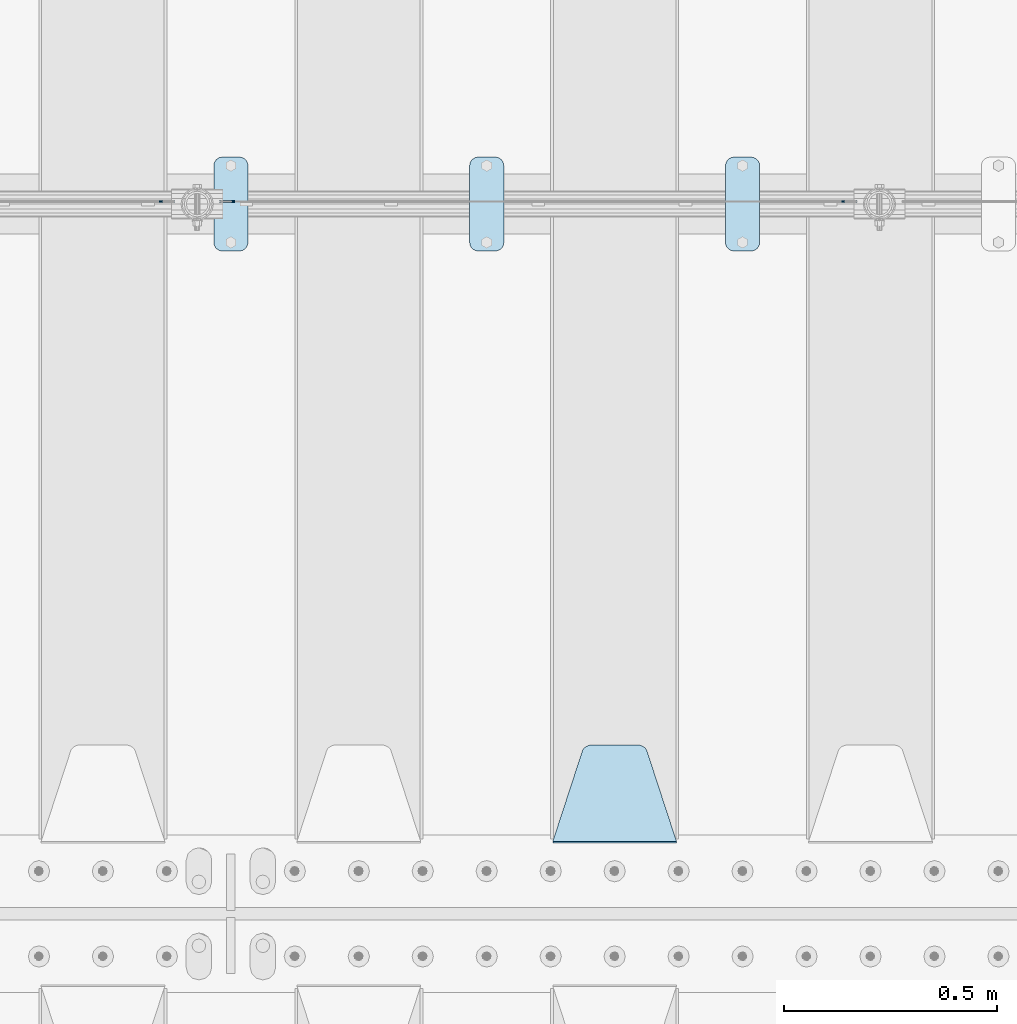
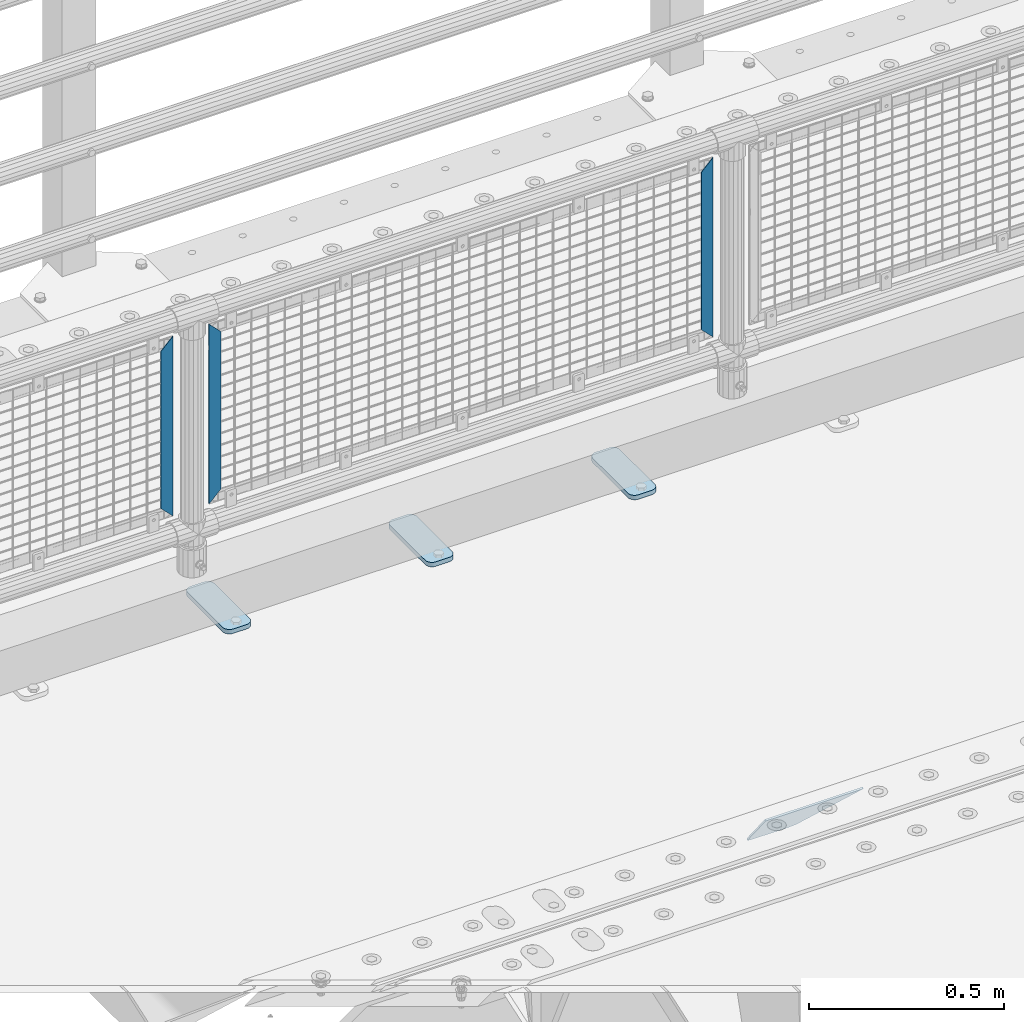
# One storey, part 174 of 208: 7 plates.
"""IFC2X3 building model written with IfcOpenShell, lengths in millimetres."""

from ifc_helpers import new_model, si_unit, frame, origin_with_axes, place, context, subcontext, project, spatial, faceted_brep, material, type_object, element, save


model = new_model("IFC2X3")

# Units and contexts
model_context = context("Model", 3, precision=1e-05, world=origin_with_axes())
body_context = subcontext(model_context, "Body", "Model", "MODEL_VIEW")
ifc_project = project(units=[si_unit("LENGTHUNIT", "METRE", prefix="MILLI"), si_unit("AREAUNIT", "SQUARE_METRE"), si_unit("VOLUMEUNIT", "CUBIC_METRE"), si_unit("MASSUNIT", "GRAM", prefix="KILO"), si_unit("TIMEUNIT", "SECOND"), si_unit("PLANEANGLEUNIT", "RADIAN"), si_unit("SOLIDANGLEUNIT", "STERADIAN"), si_unit("THERMODYNAMICTEMPERATUREUNIT", "DEGREE_CELSIUS"), si_unit("LUMINOUSINTENSITYUNIT", "LUMEN")], contexts=[model_context])

# Site, building, storey
site_placement = place(None, origin_with_axes())
site = spatial("IfcSite", under=ifc_project, at=site_placement, CompositionType="ELEMENT")
building_placement = place(site_placement, origin_with_axes())
building = spatial("IfcBuilding", under=site, at=building_placement, Name="Standard", CompositionType="ELEMENT")
storey_placement = place(building_placement, origin_with_axes())
storey = spatial("IfcBuildingStorey", under=building, at=storey_placement, Name="Undefined", CompositionType="ELEMENT", Elevation=0.0)

# Plates
ifc_material_1 = material(Name="STEEL/S355J2")
plate_type_1 = type_object("IfcPlateType", PredefinedType="NOTDEFINED")
plate_1_placement = place(storey_placement, frame((-35790.0, 4774.5, 21.0199999999977), z_axis=(1.0, 0.0, 0.0), x_axis=(0.0, -1.0, 0.0)))
element("IfcPlate", 1, at=plate_1_placement, inside=storey, type_object=plate_type_1, material=ifc_material_1, context=body_context, shape_type="Brep", body=[
    faceted_brep([(0.0, -7.0, 20.0), (0.0, -7.0, 60.0), (0.0, 7.0, 60.0), (0.0, 7.0, 20.0), (0.384294391935327, -7.0, 63.9018064403208), (0.384294391935327, 7.0, 63.9018064403208), (1.52240934977453, -7.0, 67.6536686473009), (1.52240934977453, 7.0, 67.6536686473009), (3.37060775394912, -7.0, 71.1114046603907), (3.37060775394912, 7.0, 71.1114046603907), (5.85786437626939, -7.0, 74.1421356237297), (5.85786437626939, 7.0, 74.1421356237297), (8.8885953396084, -7.0, 76.62939224605), (8.8885953396084, 7.0, 76.62939224605), (12.3463313526981, -7.0, 78.4775906502255), (12.3463313526981, 7.0, 78.4775906502255), (16.0981935596774, -7.0, 79.6157056080629), (16.0981935596774, 7.0, 79.6157056080629), (20.0, -7.0, 80.0), (20.0, 7.0, 80.0), (200.0, -7.0, 80.0), (200.0, 7.0, 80.0), (203.901806440323, -7.0, 79.6157056080629), (203.901806440323, 7.0, 79.6157056080629), (207.653668647302, -7.0, 78.4775906502255), (207.653668647302, 7.0, 78.4775906502255), (211.111404660393, -7.0, 76.62939224605), (211.111404660393, 7.0, 76.62939224605), (214.142135623731, -7.0, 74.1421356237297), (214.142135623731, 7.0, 74.1421356237297), (216.629392246051, -7.0, 71.1114046603907), (216.629392246051, 7.0, 71.1114046603907), (218.477590650225, -7.0, 67.6536686473009), (218.477590650225, 7.0, 67.6536686473009), (219.615705608065, -7.0, 63.9018064403208), (219.615705608065, 7.0, 63.9018064403208), (220.0, -7.0, 60.0), (220.0, 7.0, 60.0), (220.0, -7.0, 20.0), (220.0, 7.0, 20.0), (219.615705608065, -7.0, 16.0981935596792), (219.615705608065, 7.0, 16.0981935596792), (218.477590650225, -7.0, 12.3463313526991), (218.477590650225, 7.0, 12.3463313526991), (216.629392246051, -7.0, 8.88859533960931), (216.629392246051, 7.0, 8.88859533960931), (214.142135623731, -7.0, 5.8578643762703), (214.142135623731, 7.0, 5.8578643762703), (211.111404660393, -7.0, 3.37060775395003), (211.111404660393, 7.0, 3.37060775395003), (207.653668647302, -7.0, 1.52240934977453), (207.653668647302, 7.0, 1.52240934977453), (203.901806440323, -7.0, 0.384294391937146), (203.901806440323, 7.0, 0.384294391937146), (200.0, -7.0, 0.0), (200.0, 7.0, 0.0), (20.0, -7.0, 0.0), (20.0, 7.0, 0.0), (16.0981935596774, -7.0, 0.384294391937146), (16.0981935596774, 7.0, 0.384294391937146), (12.3463313526981, -7.0, 1.52240934977453), (12.3463313526981, 7.0, 1.52240934977453), (8.8885953396084, -7.0, 3.37060775395003), (8.8885953396084, 7.0, 3.37060775395003), (5.85786437626939, -7.0, 5.8578643762703), (5.85786437626939, 7.0, 5.8578643762703), (3.37060775394912, -7.0, 8.88859533960931), (3.37060775394912, 7.0, 8.88859533960931), (1.52240934977453, -7.0, 12.3463313526991), (1.52240934977453, 7.0, 12.3463313526991), (0.384294391935327, -7.0, 16.0981935596792), (0.384294391935327, 7.0, 16.0981935596792)], [[[0, 1, 2, 3]], [[1, 4, 5, 2]], [[4, 6, 7, 5]], [[6, 8, 9, 7]], [[8, 10, 11, 9]], [[10, 12, 13, 11]], [[12, 14, 15, 13]], [[14, 16, 17, 15]], [[16, 18, 19, 17]], [[18, 20, 21, 19]], [[20, 22, 23, 21]], [[22, 24, 25, 23]], [[24, 26, 27, 25]], [[26, 28, 29, 27]], [[28, 30, 31, 29]], [[30, 32, 33, 31]], [[32, 34, 35, 33]], [[34, 36, 37, 35]], [[36, 38, 39, 37]], [[38, 40, 41, 39]], [[40, 42, 43, 41]], [[42, 44, 45, 43]], [[44, 46, 47, 45]], [[46, 48, 49, 47]], [[48, 50, 51, 49]], [[50, 52, 53, 51]], [[52, 54, 55, 53]], [[54, 56, 57, 55]], [[56, 58, 59, 57]], [[58, 60, 61, 59]], [[60, 62, 63, 61]], [[62, 64, 65, 63]], [[64, 66, 67, 65]], [[66, 68, 69, 67]], [[68, 70, 71, 69]], [[70, 0, 3, 71]], [[5, 7, 9, 11, 13, 15, 17, 19, 21, 23, 25, 27, 29, 31, 33, 35, 37, 39, 41, 43, 45, 47, 49, 51, 53, 55, 57, 59, 61, 63, 65, 67, 69, 71, 3, 2]], [[70, 68, 66, 64, 62, 60, 58, 56, 54, 52, 50, 48, 46, 44, 42, 40, 38, 36, 34, 32, 30, 28, 26, 24, 22, 20, 18, 16, 14, 12, 10, 8, 6, 4, 1, 0]]]),
])
plate_2_placement = place(storey_placement, frame((-36390.0, 4774.5, 21.0199999999977), z_axis=(1.0, 0.0, 0.0), x_axis=(0.0, -1.0, 0.0)))
element("IfcPlate", 2, at=plate_2_placement, inside=storey, type_object=plate_type_1, material=ifc_material_1, context=body_context, shape_type="Brep", body=[
    faceted_brep([(0.0, -7.0, 20.0), (0.0, -7.0, 60.0), (0.0, 7.0, 60.0), (0.0, 7.0, 20.0), (0.384294391935327, -7.0, 63.9018064403208), (0.384294391935327, 7.0, 63.9018064403208), (1.52240934977453, -7.0, 67.6536686473009), (1.52240934977453, 7.0, 67.6536686473009), (3.37060775394912, -7.0, 71.1114046603907), (3.37060775394912, 7.0, 71.1114046603907), (5.85786437626939, -7.0, 74.1421356237297), (5.85786437626939, 7.0, 74.1421356237297), (8.8885953396084, -7.0, 76.62939224605), (8.8885953396084, 7.0, 76.62939224605), (12.3463313526981, -7.0, 78.4775906502255), (12.3463313526981, 7.0, 78.4775906502255), (16.0981935596774, -7.0, 79.6157056080629), (16.0981935596774, 7.0, 79.6157056080629), (20.0, -7.0, 80.0), (20.0, 7.0, 80.0), (200.0, -7.0, 80.0), (200.0, 7.0, 80.0), (203.901806440323, -7.0, 79.6157056080629), (203.901806440323, 7.0, 79.6157056080629), (207.653668647302, -7.0, 78.4775906502255), (207.653668647302, 7.0, 78.4775906502255), (211.111404660393, -7.0, 76.62939224605), (211.111404660393, 7.0, 76.62939224605), (214.142135623731, -7.0, 74.1421356237297), (214.142135623731, 7.0, 74.1421356237297), (216.629392246051, -7.0, 71.1114046603907), (216.629392246051, 7.0, 71.1114046603907), (218.477590650225, -7.0, 67.6536686473009), (218.477590650225, 7.0, 67.6536686473009), (219.615705608065, -7.0, 63.9018064403208), (219.615705608065, 7.0, 63.9018064403208), (220.0, -7.0, 60.0), (220.0, 7.0, 60.0), (220.0, -7.0, 20.0), (220.0, 7.0, 20.0), (219.615705608065, -7.0, 16.0981935596792), (219.615705608065, 7.0, 16.0981935596792), (218.477590650225, -7.0, 12.3463313526991), (218.477590650225, 7.0, 12.3463313526991), (216.629392246051, -7.0, 8.88859533960931), (216.629392246051, 7.0, 8.88859533960931), (214.142135623731, -7.0, 5.8578643762703), (214.142135623731, 7.0, 5.8578643762703), (211.111404660393, -7.0, 3.37060775395003), (211.111404660393, 7.0, 3.37060775395003), (207.653668647302, -7.0, 1.52240934977453), (207.653668647302, 7.0, 1.52240934977453), (203.901806440323, -7.0, 0.384294391937146), (203.901806440323, 7.0, 0.384294391937146), (200.0, -7.0, 0.0), (200.0, 7.0, 0.0), (20.0, -7.0, 0.0), (20.0, 7.0, 0.0), (16.0981935596774, -7.0, 0.384294391937146), (16.0981935596774, 7.0, 0.384294391937146), (12.3463313526981, -7.0, 1.52240934977453), (12.3463313526981, 7.0, 1.52240934977453), (8.8885953396084, -7.0, 3.37060775395003), (8.8885953396084, 7.0, 3.37060775395003), (5.85786437626939, -7.0, 5.8578643762703), (5.85786437626939, 7.0, 5.8578643762703), (3.37060775394912, -7.0, 8.88859533960931), (3.37060775394912, 7.0, 8.88859533960931), (1.52240934977453, -7.0, 12.3463313526991), (1.52240934977453, 7.0, 12.3463313526991), (0.384294391935327, -7.0, 16.0981935596792), (0.384294391935327, 7.0, 16.0981935596792)], [[[0, 1, 2, 3]], [[1, 4, 5, 2]], [[4, 6, 7, 5]], [[6, 8, 9, 7]], [[8, 10, 11, 9]], [[10, 12, 13, 11]], [[12, 14, 15, 13]], [[14, 16, 17, 15]], [[16, 18, 19, 17]], [[18, 20, 21, 19]], [[20, 22, 23, 21]], [[22, 24, 25, 23]], [[24, 26, 27, 25]], [[26, 28, 29, 27]], [[28, 30, 31, 29]], [[30, 32, 33, 31]], [[32, 34, 35, 33]], [[34, 36, 37, 35]], [[36, 38, 39, 37]], [[38, 40, 41, 39]], [[40, 42, 43, 41]], [[42, 44, 45, 43]], [[44, 46, 47, 45]], [[46, 48, 49, 47]], [[48, 50, 51, 49]], [[50, 52, 53, 51]], [[52, 54, 55, 53]], [[54, 56, 57, 55]], [[56, 58, 59, 57]], [[58, 60, 61, 59]], [[60, 62, 63, 61]], [[62, 64, 65, 63]], [[64, 66, 67, 65]], [[66, 68, 69, 67]], [[68, 70, 71, 69]], [[70, 0, 3, 71]], [[5, 7, 9, 11, 13, 15, 17, 19, 21, 23, 25, 27, 29, 31, 33, 35, 37, 39, 41, 43, 45, 47, 49, 51, 53, 55, 57, 59, 61, 63, 65, 67, 69, 71, 3, 2]], [[70, 68, 66, 64, 62, 60, 58, 56, 54, 52, 50, 48, 46, 44, 42, 40, 38, 36, 34, 32, 30, 28, 26, 24, 22, 20, 18, 16, 14, 12, 10, 8, 6, 4, 1, 0]]]),
])
plate_3_placement = place(storey_placement, frame((-36990.0, 4774.5, 21.0199999999977), z_axis=(1.0, 0.0, 0.0), x_axis=(0.0, -1.0, 0.0)))
element("IfcPlate", 3, at=plate_3_placement, inside=storey, type_object=plate_type_1, material=ifc_material_1, context=body_context, shape_type="Brep", body=[
    faceted_brep([(0.0, -7.0, 20.0), (0.0, -7.0, 60.0), (0.0, 7.0, 60.0), (0.0, 7.0, 20.0), (0.384294391935327, -7.0, 63.9018064403208), (0.384294391935327, 7.0, 63.9018064403208), (1.52240934977453, -7.0, 67.6536686473009), (1.52240934977453, 7.0, 67.6536686473009), (3.37060775394912, -7.0, 71.1114046603907), (3.37060775394912, 7.0, 71.1114046603907), (5.85786437626939, -7.0, 74.1421356237297), (5.85786437626939, 7.0, 74.1421356237297), (8.8885953396084, -7.0, 76.62939224605), (8.8885953396084, 7.0, 76.62939224605), (12.3463313526981, -7.0, 78.4775906502255), (12.3463313526981, 7.0, 78.4775906502255), (16.0981935596774, -7.0, 79.6157056080629), (16.0981935596774, 7.0, 79.6157056080629), (20.0, -7.0, 80.0), (20.0, 7.0, 80.0), (200.0, -7.0, 80.0), (200.0, 7.0, 80.0), (203.901806440323, -7.0, 79.6157056080629), (203.901806440323, 7.0, 79.6157056080629), (207.653668647302, -7.0, 78.4775906502255), (207.653668647302, 7.0, 78.4775906502255), (211.111404660393, -7.0, 76.62939224605), (211.111404660393, 7.0, 76.62939224605), (214.142135623731, -7.0, 74.1421356237297), (214.142135623731, 7.0, 74.1421356237297), (216.629392246051, -7.0, 71.1114046603907), (216.629392246051, 7.0, 71.1114046603907), (218.477590650225, -7.0, 67.6536686473009), (218.477590650225, 7.0, 67.6536686473009), (219.615705608065, -7.0, 63.9018064403208), (219.615705608065, 7.0, 63.9018064403208), (220.0, -7.0, 60.0), (220.0, 7.0, 60.0), (220.0, -7.0, 20.0), (220.0, 7.0, 20.0), (219.615705608065, -7.0, 16.0981935596792), (219.615705608065, 7.0, 16.0981935596792), (218.477590650225, -7.0, 12.3463313526991), (218.477590650225, 7.0, 12.3463313526991), (216.629392246051, -7.0, 8.88859533960931), (216.629392246051, 7.0, 8.88859533960931), (214.142135623731, -7.0, 5.8578643762703), (214.142135623731, 7.0, 5.8578643762703), (211.111404660393, -7.0, 3.37060775395003), (211.111404660393, 7.0, 3.37060775395003), (207.653668647302, -7.0, 1.52240934977453), (207.653668647302, 7.0, 1.52240934977453), (203.901806440323, -7.0, 0.384294391937146), (203.901806440323, 7.0, 0.384294391937146), (200.0, -7.0, 0.0), (200.0, 7.0, 0.0), (20.0, -7.0, 0.0), (20.0, 7.0, 0.0), (16.0981935596774, -7.0, 0.384294391937146), (16.0981935596774, 7.0, 0.384294391937146), (12.3463313526981, -7.0, 1.52240934977453), (12.3463313526981, 7.0, 1.52240934977453), (8.8885953396084, -7.0, 3.37060775395003), (8.8885953396084, 7.0, 3.37060775395003), (5.85786437626939, -7.0, 5.8578643762703), (5.85786437626939, 7.0, 5.8578643762703), (3.37060775394912, -7.0, 8.88859533960931), (3.37060775394912, 7.0, 8.88859533960931), (1.52240934977453, -7.0, 12.3463313526991), (1.52240934977453, 7.0, 12.3463313526991), (0.384294391935327, -7.0, 16.0981935596792), (0.384294391935327, 7.0, 16.0981935596792)], [[[0, 1, 2, 3]], [[1, 4, 5, 2]], [[4, 6, 7, 5]], [[6, 8, 9, 7]], [[8, 10, 11, 9]], [[10, 12, 13, 11]], [[12, 14, 15, 13]], [[14, 16, 17, 15]], [[16, 18, 19, 17]], [[18, 20, 21, 19]], [[20, 22, 23, 21]], [[22, 24, 25, 23]], [[24, 26, 27, 25]], [[26, 28, 29, 27]], [[28, 30, 31, 29]], [[30, 32, 33, 31]], [[32, 34, 35, 33]], [[34, 36, 37, 35]], [[36, 38, 39, 37]], [[38, 40, 41, 39]], [[40, 42, 43, 41]], [[42, 44, 45, 43]], [[44, 46, 47, 45]], [[46, 48, 49, 47]], [[48, 50, 51, 49]], [[50, 52, 53, 51]], [[52, 54, 55, 53]], [[54, 56, 57, 55]], [[56, 58, 59, 57]], [[58, 60, 61, 59]], [[60, 62, 63, 61]], [[62, 64, 65, 63]], [[64, 66, 67, 65]], [[66, 68, 69, 67]], [[68, 70, 71, 69]], [[70, 0, 3, 71]], [[5, 7, 9, 11, 13, 15, 17, 19, 21, 23, 25, 27, 29, 31, 33, 35, 37, 39, 41, 43, 45, 47, 49, 51, 53, 55, 57, 59, 61, 63, 65, 67, 69, 71, 3, 2]], [[70, 68, 66, 64, 62, 60, 58, 56, 54, 52, 50, 48, 46, 44, 42, 40, 38, 36, 34, 32, 30, 28, 26, 24, 22, 20, 18, 16, 14, 12, 10, 8, 6, 4, 1, 0]]]),
])
ifc_material_2 = material(Name="STEEL/S355N")
plate_type_2 = type_object("IfcPlateType", PredefinedType="NOTDEFINED")
plate_4_placement = place(storey_placement, frame((-35905.0, 3168.23223304702, -1.76776695296758), z_axis=(0.0, 0.707106781186547, -0.707106781186548), x_axis=(-1.0, 0.0, 0.0)))
element("IfcPlate", 4, at=plate_4_placement, inside=storey, type_object=plate_type_2, material=ifc_material_2, context=body_context, shape_type="Brep", body=[
    faceted_brep([(0.0, -2.5, 0.0), (69.345504679477, -2.5, 300.17173142483), (69.345504679477, 2.5, 300.17173142483), (0.0, 2.5, 0.0), (70.9274061199576, -2.5, 304.897442415399), (70.9274061199576, 2.5, 304.8974424154), (73.3818627772307, -2.5, 309.234538108527), (73.3818627772307, 2.5, 309.234538108527), (76.6187032999551, -2.5, 313.023683126103), (76.6187032999551, 2.5, 313.023683126103), (80.5190132704993, -2.5, 316.125672595371), (80.5190132704993, 2.5, 316.125672595371), (84.9395038596849, -2.5, 318.426546230476), (84.9395038596849, 2.50000000000091, 318.426546230476), (89.7177759439219, -2.5, 319.841774983275), (89.7177759439219, 2.50000000000091, 319.841774983275), (94.678286292652, -2.49999999999909, 320.319366455078), (94.678286292652, 2.5, 320.319366455078), (195.321713707348, -2.49999999999909, 320.319366455078), (195.321713707348, 2.5, 320.319366455078), (200.282224056078, -2.5, 319.841774983275), (200.282224056078, 2.5, 319.841774983274), (205.060496140315, -2.5, 318.426546230475), (205.060496140315, 2.5, 318.426546230475), (209.480986729501, -2.5, 316.125672595371), (209.480986729501, 2.50000000000091, 316.125672595371), (213.381296700045, -2.5, 313.023683126102), (213.381296700045, 2.5, 313.023683126102), (216.618137222769, -2.5, 309.234538108526), (216.618137222769, 2.5, 309.234538108527), (219.072593880042, -2.5, 304.897442415399), (219.072593880042, 2.5, 304.897442415399), (220.654495320523, -2.5, 300.17173142483), (220.654495320523, 2.5, 300.17173142483), (290.0, -2.5, 0.0), (290.0, 2.5, 0.0)], [[[0, 1, 2, 3]], [[1, 4, 5, 2]], [[4, 6, 7, 5]], [[6, 8, 9, 7]], [[8, 10, 11, 9]], [[10, 12, 13, 11]], [[12, 14, 15, 13]], [[14, 16, 17, 15]], [[16, 18, 19, 17]], [[18, 20, 21, 19]], [[20, 22, 23, 21]], [[22, 24, 25, 23]], [[24, 26, 27, 25]], [[26, 28, 29, 27]], [[28, 30, 31, 29]], [[30, 32, 33, 31]], [[32, 34, 35, 33]], [[34, 0, 3, 35]], [[5, 7, 9, 11, 13, 15, 17, 19, 21, 23, 25, 27, 29, 31, 33, 35, 3, 2]], [[34, 32, 30, 28, 26, 24, 22, 20, 18, 16, 14, 12, 10, 8, 6, 4, 1, 0]]]),
])
ifc_material_3 = material(Name="Misc_Undefined")
plate_type_3 = type_object("IfcPlateType", PredefinedType="NOTDEFINED")
plate_5_placement = place(storey_placement, frame((-36940.490286459, 4670.5, 879.519963133601), z_axis=(-0.707008801899319, 0.0, -0.707204746899291), x_axis=(-0.70720474689929, 0.0, 0.707008801899319)))
element("IfcPlate", 5, at=plate_5_placement, inside=storey, type_object=plate_type_3, material=ifc_material_3, context=body_context, shape_type="Brep", body=[
    faceted_brep([(0.0, -1.49999999999909, 3.63797880709171e-12), (-348.55218505859, -1.5, 348.655029296875), (-348.55218505859, 1.5, 348.655029296875), (0.0, 1.50000000000182, 3.63797880709171e-12), (-348.544891357418, -1.5, 398.152496337894), (-348.544891357418, 1.5, 398.152496337894), (49.5043945312536, -1.5, 7.6397554948926e-11), (49.5043945312536, 1.5, 7.6397554948926e-11)], [[[0, 1, 2, 3]], [[1, 4, 5, 2]], [[4, 6, 7, 5]], [[6, 0, 3, 7]], [[5, 7, 3, 2]], [[6, 4, 1, 0]]]),
])
for number, where, z_axis, x_axis in (
    (6, (-35517.5003125164, 4670.5, 879.52), (0.707103624179499, 0.0, -0.707109938179501), (0.707109938179495, 0.0, 0.707103624179505)),
    (7, (-37117.5003125164, 4670.5, 879.52), (0.707103624179499, 0.0, -0.707109938179501), (0.707109938179495, 0.0, 0.707103624179505)),
):
    element("IfcPlate", number, at=place(storey_placement, frame(where, z_axis=z_axis, x_axis=x_axis)), inside=storey, type_object=plate_type_3, material=ifc_material_3, context=body_context, shape_type="Brep", body=[
        faceted_brep([(0.0, -1.49999999999909, 3.63797880709171e-12), (-348.605163574219, -1.5, 348.602081298821), (-348.605163574219, 1.5, 348.602081298821), (0.0, 1.50000000000182, 3.63797880709171e-12), (-348.605163574219, -1.5, 398.099334716793), (-348.605163574219, 1.5, 398.099334716793), (49.4976959228516, -1.5, 6.91215973347425e-11), (49.4976959228516, 1.5, 6.91215973347425e-11)], [[[0, 1, 2, 3]], [[1, 4, 5, 2]], [[4, 6, 7, 5]], [[6, 0, 3, 7]], [[5, 7, 3, 2]], [[6, 4, 1, 0]]]),
    ])

save(model, "model.ifc")
